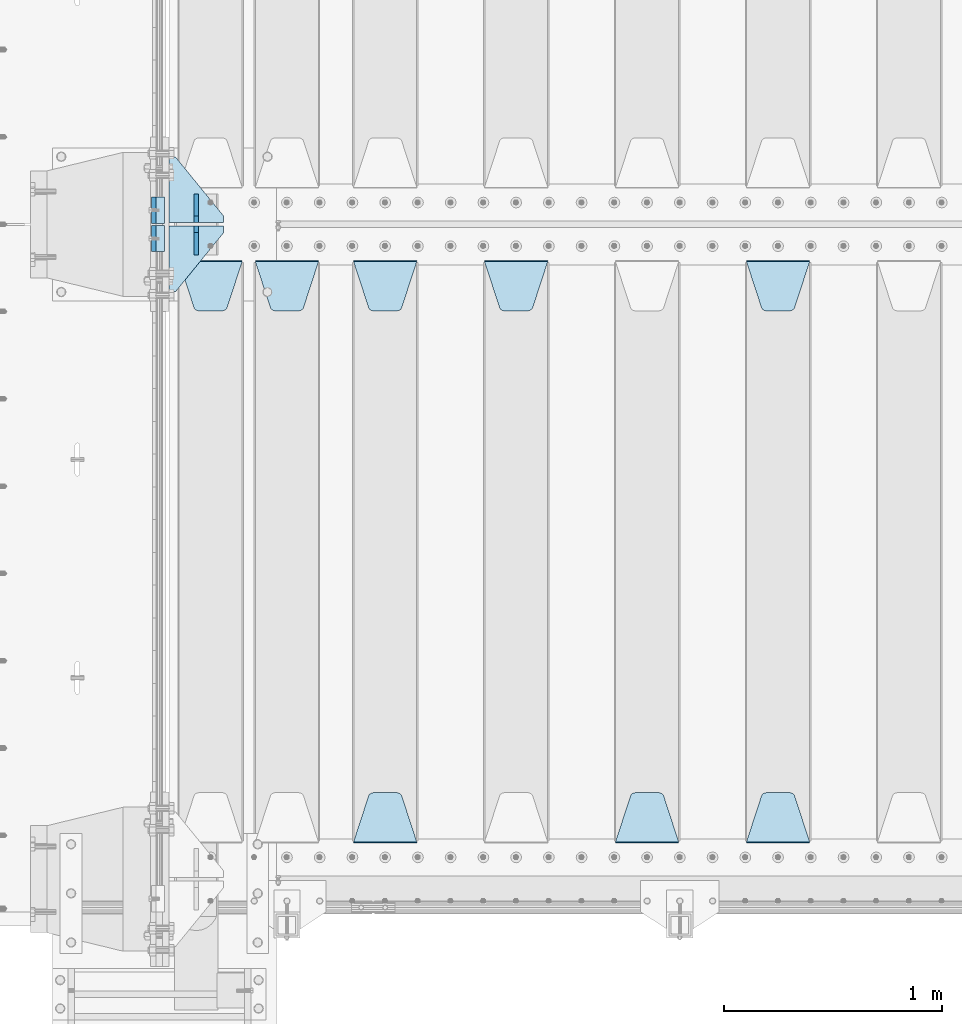
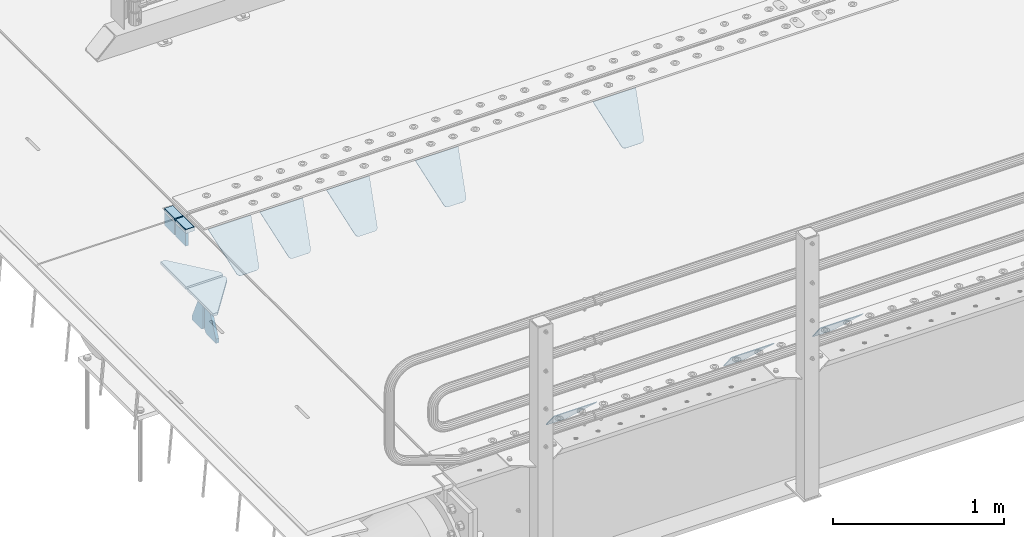
# One storey, part 155 of 193: 16 plates.
"""IFC2X3 building model written with IfcOpenShell, lengths in millimetres."""

from ifc_helpers import new_model, si_unit, frame, origin_with_axes, place, context, subcontext, project, spatial, faceted_brep, material, type_object, element, save


model = new_model("IFC2X3")

# Units and contexts
model_context = context("Model", 3, precision=1e-05, world=origin_with_axes())
body_context = subcontext(model_context, "Body", "Model", "MODEL_VIEW")
ifc_project = project(units=[si_unit("LENGTHUNIT", "METRE", prefix="MILLI"), si_unit("AREAUNIT", "SQUARE_METRE"), si_unit("VOLUMEUNIT", "CUBIC_METRE"), si_unit("MASSUNIT", "GRAM", prefix="KILO"), si_unit("TIMEUNIT", "SECOND"), si_unit("PLANEANGLEUNIT", "RADIAN"), si_unit("SOLIDANGLEUNIT", "STERADIAN"), si_unit("THERMODYNAMICTEMPERATUREUNIT", "DEGREE_CELSIUS"), si_unit("LUMINOUSINTENSITYUNIT", "LUMEN")], contexts=[model_context])

# Site, building, storey
site_placement = place(None, origin_with_axes())
site = spatial("IfcSite", under=ifc_project, at=site_placement, CompositionType="ELEMENT")
building_placement = place(site_placement, origin_with_axes())
building = spatial("IfcBuilding", under=site, at=building_placement, Name="Standard", CompositionType="ELEMENT")
storey_placement = place(building_placement, origin_with_axes())
storey = spatial("IfcBuildingStorey", under=building, at=storey_placement, Name="Undefined", CompositionType="ELEMENT", Elevation=0.0)

# Plates
ifc_material_1 = material()
plate_type_1 = type_object("IfcPlateType", PredefinedType="NOTDEFINED")
plate_1_placement = place(storey_placement, frame((-42460.0, 26935.0000000001, -16.0000763080427), z_axis=(-1.0, 0.0, 0.0), x_axis=(0.0, 0.0, 1.0)))
element("IfcPlate", 1, at=plate_1_placement, inside=storey, type_object=plate_type_1, material=ifc_material_1, context=body_context, shape_type="Brep", body=[
    faceted_brep([(3.5527136788005e-15, -60.0, 0.0), (2.49929144047201e-09, -60.0, 60.0), (2.49929144047201e-09, 60.0000000000036, 60.0), (0.0, 60.0, -7.27595761418343e-12), (25.0146748218828, -60.0, 60.0), (25.0146748218828, 60.0, 60.0), (26.5597449794466, -60.0, 59.7552873949098), (26.5597449794466, 60.0000000000036, 59.7552873949098), (27.9535758796897, -59.9999999999964, 59.0451032832789), (27.9535758796897, 60.0000000000036, 59.0451032832789), (29.0597323263517, -60.0, 57.9389640667287), (29.0597323263517, 60.0, 57.9389640667287), (29.7699381491534, -60.0, 56.5451442289705), (29.7699381491534, 60.0, 56.5451442289705), (30.0146748212763, -60.0, 55.0000778834001), (30.0146748212763, 60.0, 55.0000778834001), (30.0154536553013, -59.9999999999964, 5.00007788340736), (30.0154536553013, 60.0000000000036, 5.00007788340736), (29.7707554908505, -60.0, 3.45497428546514), (29.7707554908505, 60.0, 3.45497428546514), (29.0605660948355, -60.0, 2.06111154406972), (29.0605660948355, 60.0, 2.06111154406972), (27.9544051209123, -59.9999999999964, 0.954933339693525), (27.9544051209123, 60.0000000000036, 0.954933339693525), (26.5605534420796, -60.0, 0.244722232011554), (26.5605534420796, 60.0, 0.244722232011554), (25.0154536559091, -60.0, 7.27595761418343e-12), (25.0154536559091, 60.0, 7.27595761418343e-12)], [[[0, 1, 2, 3]], [[1, 4, 5, 2]], [[4, 6, 7, 5]], [[6, 8, 9, 7]], [[8, 10, 11, 9]], [[10, 12, 13, 11]], [[12, 14, 15, 13]], [[14, 16, 17, 15]], [[16, 18, 19, 17]], [[18, 20, 21, 19]], [[20, 22, 23, 21]], [[22, 24, 25, 23]], [[24, 26, 27, 25]], [[26, 0, 3, 27]], [[5, 7, 9, 11, 13, 15, 17, 19, 21, 23, 25, 27, 3, 2]], [[26, 24, 22, 20, 18, 16, 14, 12, 10, 8, 6, 4, 1, 0]]]),
])
plate_2_placement = place(storey_placement, frame((-42460.0000000646, 27065.0000004321, -15.999743219274), z_axis=(-1.0, 0.0, 0.0), x_axis=(0.0, -4.95099997756316e-06, 0.999999999987744)))
element("IfcPlate", 2, at=plate_2_placement, inside=storey, type_object=plate_type_1, material=ifc_material_1, context=body_context, shape_type="Brep", body=[
    faceted_brep([(3.5527136788005e-15, -60.0, 0.0), (-0.000933120085687023, -60.0, 60.0), (-0.000933120085687023, 60.0, 59.9999999999927), (0.0, 60.0, -7.27595761418343e-12), (24.9991450303709, -60.0, 60.0), (24.9991450303709, 60.0, 59.9999999999927), (26.544215218168, -60.0000000000036, 59.7552873850873), (26.544215218168, 60.0, 59.75528738508), (27.9380461396139, -60.0000000000036, 59.0451032459096), (27.9380461396139, 60.0, 59.0451032459096), (29.0442025908961, -60.0000000000036, 57.9389639895744), (29.0442025908961, 60.0, 57.9389639895744), (29.7544083969366, -60.0, 56.5451441080368), (29.7544083969366, 60.0, 56.5451441080295), (29.9991450297669, -60.0000000000036, 55.0000777244568), (29.9991450297669, 60.0, 55.0000777244495), (29.999922274335, -60.0, 5.00007772445679), (29.999922274335, 59.9999999999964, 5.00007772444951), (29.7552240705896, -60.0, 3.45497416452417), (29.7552240705896, 60.0000000000036, 3.45497416452417), (29.0450346578116, -60.0, 2.06111146690819), (29.0450346578116, 59.9999999999964, 2.06111146690819), (27.9388736885072, -60.0000000000036, 0.954933302316931), (27.9388736885072, 59.9999999999964, 0.954933302316931), (26.5450220308766, -60.0000000000036, 0.244722222181736), (26.5450220308766, 60.0, 0.244722222181736), (24.9999222749392, -60.0, 0.0), (24.9999222749392, 60.0, -7.27595761418343e-12)], [[[0, 1, 2, 3]], [[1, 4, 5, 2]], [[4, 6, 7, 5]], [[6, 8, 9, 7]], [[8, 10, 11, 9]], [[10, 12, 13, 11]], [[12, 14, 15, 13]], [[14, 16, 17, 15]], [[16, 18, 19, 17]], [[18, 20, 21, 19]], [[20, 22, 23, 21]], [[22, 24, 25, 23]], [[24, 26, 27, 25]], [[26, 0, 3, 27]], [[5, 7, 9, 11, 13, 15, 17, 19, 21, 23, 25, 27, 3, 2]], [[26, 24, 22, 20, 18, 16, 14, 12, 10, 8, 6, 4, 1, 0]]]),
])
ifc_material_2 = material(Name="STEEL/S355N")
plate_type_2 = type_object("IfcPlateType", PredefinedType="NOTDEFINED")
plate_3_placement = place(storey_placement, frame((-42510.0, 26995.0000855345, -105.984410846883), z_axis=(0.0, -1.0, 0.0), x_axis=(0.0, 0.0, 1.0)))
element("IfcPlate", 3, at=plate_3_placement, inside=storey, type_object=plate_type_2, material=ifc_material_2, context=body_context, shape_type="Brep", body=[
    faceted_brep([(0.0, -10.0, 0.0), (5.70725632087488e-07, -10.0, 120.0), (5.70725632087488e-07, 10.0, 120.0), (0.0, 10.0, 0.0), (89.9845046997066, -10.0, 120.000000000004), (89.9845046997066, 10.0, 120.000000000004), (89.9843902587891, -10.0, 6.54836185276508e-11), (89.9843902587891, 10.0, 6.54836185276508e-11)], [[[0, 1, 2, 3]], [[1, 4, 5, 2]], [[4, 6, 7, 5]], [[6, 0, 3, 7]], [[5, 7, 3, 2]], [[6, 4, 1, 0]]]),
])
plate_4_placement = place(storey_placement, frame((-42510.0, 27125.0004459811, -106.000068249326), z_axis=(1.0000003385235e-09, -0.999999999987744, -4.95099999993936e-06), x_axis=(0.0, -4.95099997756316e-06, 0.999999999987744)))
element("IfcPlate", 4, at=plate_4_placement, inside=storey, type_object=plate_type_2, material=ifc_material_2, context=body_context, shape_type="Brep", body=[
    faceted_brep([(0.0, -10.0, 0.0), (5.70725632087488e-07, -10.0, 120.0), (5.70725632087488e-07, 10.0, 120.0), (0.0, 10.0, 0.0), (89.9999999999979, -10.0, 120.000000000004), (89.9999999999979, 10.0, 120.000000000004), (90.0, -10.0, 1.09139364212751e-11), (90.0, 10.0, 1.09139364212751e-11)], [[[0, 1, 2, 3]], [[1, 4, 5, 2]], [[4, 6, 7, 5]], [[6, 0, 3, 7]], [[5, 7, 3, 2]], [[6, 4, 1, 0]]]),
])
plate_type_3 = type_object("IfcPlateType", PredefinedType="NOTDEFINED")
plate_5_placement = place(storey_placement, frame((-39795.0, 26831.767766956, -1.76776695296758), z_axis=(0.0, -0.707106781186547, -0.707106781186548), x_axis=(1.0, 0.0, 0.0)))
element("IfcPlate", 5, at=plate_5_placement, inside=storey, type_object=plate_type_3, material=ifc_material_2, context=body_context, shape_type="Brep", body=[
    faceted_brep([(0.0, -2.5, 0.0), (69.345504679477, -2.50000000000364, 300.171731424831), (69.345504679477, 2.49999999999636, 300.171731424831), (0.0, 2.5, 0.0), (70.9274061199576, -2.50000000000364, 304.897442415397), (70.9274061199576, 2.49999999999636, 304.897442415397), (73.3818627772307, -2.50000000000364, 309.234538108529), (73.3818627772307, 2.49999999999636, 309.234538108529), (76.6187032999551, -2.50000000000728, 313.023683126103), (76.6187032999551, 2.49999999999636, 313.023683126103), (80.5190132704993, -2.50000000000364, 316.125672595372), (80.5190132704993, 2.49999999999636, 316.125672595368), (84.9395038596849, -2.50000000000364, 318.426546230472), (84.9395038596849, 2.49999999999636, 318.426546230476), (89.7177759439219, -2.50000000000364, 319.841774983273), (89.7177759439219, 2.49999999999636, 319.841774983277), (94.678286292652, -2.50000000000364, 320.319366455074), (94.678286292652, 2.49999999999636, 320.319366455074), (195.321713707348, -2.50000000000364, 320.319366455074), (195.321713707348, 2.49999999999636, 320.319366455074), (200.282224056078, -2.50000000000364, 319.841774983273), (200.282224056078, 2.49999999999636, 319.841774983277), (205.060496140315, -2.50000000000364, 318.426546230472), (205.060496140315, 2.49999999999636, 318.426546230472), (209.480986729501, -2.50000000000364, 316.125672595372), (209.480986729501, 2.49999999999636, 316.125672595368), (213.381296700045, -2.50000000000728, 313.023683126103), (213.381296700045, 2.49999999999272, 313.023683126103), (216.618137222769, -2.50000000000364, 309.234538108525), (216.618137222769, 2.49999999999636, 309.234538108522), (219.072593880042, -2.50000000000364, 304.897442415397), (219.072593880042, 2.49999999999636, 304.897442415397), (220.654495320523, -2.50000000000364, 300.171731424831), (220.654495320523, 2.49999999999636, 300.171731424831), (290.0, -2.50000000000364, 0.0), (290.0, 2.49999999999636, 0.0)], [[[0, 1, 2, 3]], [[1, 4, 5, 2]], [[4, 6, 7, 5]], [[6, 8, 9, 7]], [[8, 10, 11, 9]], [[10, 12, 13, 11]], [[12, 14, 15, 13]], [[14, 16, 17, 15]], [[16, 18, 19, 17]], [[18, 20, 21, 19]], [[20, 22, 23, 21]], [[22, 24, 25, 23]], [[24, 26, 27, 25]], [[26, 28, 29, 27]], [[28, 30, 31, 29]], [[30, 32, 33, 31]], [[32, 34, 35, 33]], [[34, 0, 3, 35]], [[5, 7, 9, 11, 13, 15, 17, 19, 21, 23, 25, 27, 29, 31, 33, 35, 3, 2]], [[34, 32, 30, 28, 26, 24, 22, 20, 18, 16, 14, 12, 10, 8, 6, 4, 1, 0]]]),
])
plate_6_placement = place(storey_placement, frame((-39505.0, 24168.232233047, -1.76776695296758), z_axis=(0.0, 0.707106781186547, -0.707106781186548), x_axis=(-1.0, 0.0, 0.0)))
element("IfcPlate", 6, at=plate_6_placement, inside=storey, type_object=plate_type_3, material=ifc_material_2, context=body_context, shape_type="Brep", body=[
    faceted_brep([(0.0, -2.5, 0.0), (69.345504679477, -2.50000000000364, 300.171731424831), (69.345504679477, 2.49999999999636, 300.171731424831), (0.0, 2.5, 0.0), (70.9274061199576, -2.50000000000364, 304.897442415397), (70.9274061199576, 2.49999999999636, 304.897442415397), (73.3818627772307, -2.50000000000364, 309.234538108529), (73.3818627772307, 2.49999999999636, 309.234538108529), (76.6187032999551, -2.50000000000728, 313.023683126103), (76.6187032999551, 2.49999999999636, 313.023683126103), (80.5190132704993, -2.50000000000364, 316.125672595372), (80.5190132704993, 2.49999999999636, 316.125672595368), (84.9395038596849, -2.50000000000364, 318.426546230472), (84.9395038596849, 2.49999999999636, 318.426546230476), (89.7177759439219, -2.50000000000364, 319.841774983273), (89.7177759439219, 2.49999999999636, 319.841774983277), (94.678286292652, -2.50000000000364, 320.319366455074), (94.678286292652, 2.49999999999636, 320.319366455074), (195.321713707348, -2.50000000000364, 320.319366455074), (195.321713707348, 2.49999999999636, 320.319366455074), (200.282224056078, -2.50000000000364, 319.841774983273), (200.282224056078, 2.49999999999636, 319.841774983277), (205.060496140315, -2.50000000000364, 318.426546230472), (205.060496140315, 2.49999999999636, 318.426546230472), (209.480986729501, -2.50000000000364, 316.125672595372), (209.480986729501, 2.49999999999636, 316.125672595368), (213.381296700045, -2.50000000000728, 313.023683126103), (213.381296700045, 2.49999999999272, 313.023683126103), (216.618137222769, -2.50000000000364, 309.234538108525), (216.618137222769, 2.49999999999636, 309.234538108522), (219.072593880042, -2.50000000000364, 304.897442415397), (219.072593880042, 2.49999999999636, 304.897442415397), (220.654495320523, -2.50000000000364, 300.171731424831), (220.654495320523, 2.49999999999636, 300.171731424831), (290.0, -2.50000000000364, 0.0), (290.0, 2.49999999999636, 0.0)], [[[0, 1, 2, 3]], [[1, 4, 5, 2]], [[4, 6, 7, 5]], [[6, 8, 9, 7]], [[8, 10, 11, 9]], [[10, 12, 13, 11]], [[12, 14, 15, 13]], [[14, 16, 17, 15]], [[16, 18, 19, 17]], [[18, 20, 21, 19]], [[20, 22, 23, 21]], [[22, 24, 25, 23]], [[24, 26, 27, 25]], [[26, 28, 29, 27]], [[28, 30, 31, 29]], [[30, 32, 33, 31]], [[32, 34, 35, 33]], [[34, 0, 3, 35]], [[5, 7, 9, 11, 13, 15, 17, 19, 21, 23, 25, 27, 29, 31, 33, 35, 3, 2]], [[34, 32, 30, 28, 26, 24, 22, 20, 18, 16, 14, 12, 10, 8, 6, 4, 1, 0]]]),
])
plate_7_placement = place(storey_placement, frame((-40105.0, 24168.232233047, -1.76776695296758), z_axis=(0.0, 0.707106781186547, -0.707106781186548), x_axis=(-1.0, 0.0, 0.0)))
element("IfcPlate", 7, at=plate_7_placement, inside=storey, type_object=plate_type_3, material=ifc_material_2, context=body_context, shape_type="Brep", body=[
    faceted_brep([(0.0, -2.5, 0.0), (69.345504679477, -2.50000000000364, 300.171731424831), (69.345504679477, 2.49999999999636, 300.171731424831), (0.0, 2.5, 0.0), (70.9274061199576, -2.50000000000364, 304.897442415397), (70.9274061199576, 2.49999999999636, 304.897442415397), (73.3818627772307, -2.50000000000364, 309.234538108529), (73.3818627772307, 2.49999999999636, 309.234538108529), (76.6187032999551, -2.50000000000728, 313.023683126103), (76.6187032999551, 2.49999999999636, 313.023683126103), (80.5190132704993, -2.50000000000364, 316.125672595372), (80.5190132704993, 2.49999999999636, 316.125672595368), (84.9395038596849, -2.50000000000364, 318.426546230472), (84.9395038596849, 2.49999999999636, 318.426546230476), (89.7177759439219, -2.50000000000364, 319.841774983273), (89.7177759439219, 2.49999999999636, 319.841774983277), (94.678286292652, -2.50000000000364, 320.319366455074), (94.678286292652, 2.49999999999636, 320.319366455074), (195.321713707348, -2.50000000000364, 320.319366455074), (195.321713707348, 2.49999999999636, 320.319366455074), (200.282224056078, -2.50000000000364, 319.841774983273), (200.282224056078, 2.49999999999636, 319.841774983277), (205.060496140315, -2.50000000000364, 318.426546230472), (205.060496140315, 2.49999999999636, 318.426546230472), (209.480986729501, -2.50000000000364, 316.125672595372), (209.480986729501, 2.49999999999636, 316.125672595368), (213.381296700045, -2.50000000000728, 313.023683126103), (213.381296700045, 2.49999999999272, 313.023683126103), (216.618137222769, -2.50000000000364, 309.234538108525), (216.618137222769, 2.49999999999636, 309.234538108522), (219.072593880042, -2.50000000000364, 304.897442415397), (219.072593880042, 2.49999999999636, 304.897442415397), (220.654495320523, -2.50000000000364, 300.171731424831), (220.654495320523, 2.49999999999636, 300.171731424831), (290.0, -2.50000000000364, 0.0), (290.0, 2.49999999999636, 0.0)], [[[0, 1, 2, 3]], [[1, 4, 5, 2]], [[4, 6, 7, 5]], [[6, 8, 9, 7]], [[8, 10, 11, 9]], [[10, 12, 13, 11]], [[12, 14, 15, 13]], [[14, 16, 17, 15]], [[16, 18, 19, 17]], [[18, 20, 21, 19]], [[20, 22, 23, 21]], [[22, 24, 25, 23]], [[24, 26, 27, 25]], [[26, 28, 29, 27]], [[28, 30, 31, 29]], [[30, 32, 33, 31]], [[32, 34, 35, 33]], [[34, 0, 3, 35]], [[5, 7, 9, 11, 13, 15, 17, 19, 21, 23, 25, 27, 29, 31, 33, 35, 3, 2]], [[34, 32, 30, 28, 26, 24, 22, 20, 18, 16, 14, 12, 10, 8, 6, 4, 1, 0]]]),
])
plate_8_placement = place(storey_placement, frame((-40995.0, 26831.767766956, -1.76776695296758), z_axis=(0.0, -0.707106781186547, -0.707106781186548), x_axis=(1.0, 0.0, 0.0)))
element("IfcPlate", 8, at=plate_8_placement, inside=storey, type_object=plate_type_3, material=ifc_material_2, context=body_context, shape_type="Brep", body=[
    faceted_brep([(0.0, -2.5, 0.0), (69.345504679477, -2.50000000000364, 300.171731424831), (69.345504679477, 2.49999999999636, 300.171731424831), (0.0, 2.5, 0.0), (70.9274061199576, -2.50000000000364, 304.897442415397), (70.9274061199576, 2.49999999999636, 304.897442415397), (73.3818627772307, -2.50000000000364, 309.234538108529), (73.3818627772307, 2.49999999999636, 309.234538108529), (76.6187032999551, -2.50000000000728, 313.023683126103), (76.6187032999551, 2.49999999999636, 313.023683126103), (80.5190132704993, -2.50000000000364, 316.125672595372), (80.5190132704993, 2.49999999999636, 316.125672595368), (84.9395038596849, -2.50000000000364, 318.426546230472), (84.9395038596849, 2.49999999999636, 318.426546230476), (89.7177759439219, -2.50000000000364, 319.841774983273), (89.7177759439219, 2.49999999999636, 319.841774983277), (94.678286292652, -2.50000000000364, 320.319366455074), (94.678286292652, 2.49999999999636, 320.319366455074), (195.321713707348, -2.50000000000364, 320.319366455074), (195.321713707348, 2.49999999999636, 320.319366455074), (200.282224056078, -2.50000000000364, 319.841774983273), (200.282224056078, 2.49999999999636, 319.841774983277), (205.060496140315, -2.50000000000364, 318.426546230472), (205.060496140315, 2.49999999999636, 318.426546230472), (209.480986729501, -2.50000000000364, 316.125672595372), (209.480986729501, 2.49999999999636, 316.125672595368), (213.381296700045, -2.50000000000728, 313.023683126103), (213.381296700045, 2.49999999999272, 313.023683126103), (216.618137222769, -2.50000000000364, 309.234538108525), (216.618137222769, 2.49999999999636, 309.234538108522), (219.072593880042, -2.50000000000364, 304.897442415397), (219.072593880042, 2.49999999999636, 304.897442415397), (220.654495320523, -2.50000000000364, 300.171731424831), (220.654495320523, 2.49999999999636, 300.171731424831), (290.0, -2.50000000000364, 0.0), (290.0, 2.49999999999636, 0.0)], [[[0, 1, 2, 3]], [[1, 4, 5, 2]], [[4, 6, 7, 5]], [[6, 8, 9, 7]], [[8, 10, 11, 9]], [[10, 12, 13, 11]], [[12, 14, 15, 13]], [[14, 16, 17, 15]], [[16, 18, 19, 17]], [[18, 20, 21, 19]], [[20, 22, 23, 21]], [[22, 24, 25, 23]], [[24, 26, 27, 25]], [[26, 28, 29, 27]], [[28, 30, 31, 29]], [[30, 32, 33, 31]], [[32, 34, 35, 33]], [[34, 0, 3, 35]], [[5, 7, 9, 11, 13, 15, 17, 19, 21, 23, 25, 27, 29, 31, 33, 35, 3, 2]], [[34, 32, 30, 28, 26, 24, 22, 20, 18, 16, 14, 12, 10, 8, 6, 4, 1, 0]]]),
])
plate_9_placement = place(storey_placement, frame((-41595.0, 26831.767766956, -1.76776695296758), z_axis=(0.0, -0.707106781186547, -0.707106781186548), x_axis=(1.0, 0.0, 0.0)))
element("IfcPlate", 9, at=plate_9_placement, inside=storey, type_object=plate_type_3, material=ifc_material_2, context=body_context, shape_type="Brep", body=[
    faceted_brep([(0.0, -2.5, 0.0), (69.345504679477, -2.50000000000364, 300.171731424831), (69.345504679477, 2.49999999999636, 300.171731424831), (0.0, 2.5, 0.0), (70.9274061199576, -2.50000000000364, 304.897442415397), (70.9274061199576, 2.49999999999636, 304.897442415397), (73.3818627772307, -2.50000000000364, 309.234538108529), (73.3818627772307, 2.49999999999636, 309.234538108529), (76.6187032999551, -2.50000000000728, 313.023683126103), (76.6187032999551, 2.49999999999636, 313.023683126103), (80.5190132704993, -2.50000000000364, 316.125672595372), (80.5190132704993, 2.49999999999636, 316.125672595368), (84.9395038596849, -2.50000000000364, 318.426546230472), (84.9395038596849, 2.49999999999636, 318.426546230476), (89.7177759439219, -2.50000000000364, 319.841774983273), (89.7177759439219, 2.49999999999636, 319.841774983277), (94.678286292652, -2.50000000000364, 320.319366455074), (94.678286292652, 2.49999999999636, 320.319366455074), (195.321713707348, -2.50000000000364, 320.319366455074), (195.321713707348, 2.49999999999636, 320.319366455074), (200.282224056078, -2.50000000000364, 319.841774983273), (200.282224056078, 2.49999999999636, 319.841774983277), (205.060496140315, -2.50000000000364, 318.426546230472), (205.060496140315, 2.49999999999636, 318.426546230472), (209.480986729501, -2.50000000000364, 316.125672595372), (209.480986729501, 2.49999999999636, 316.125672595368), (213.381296700045, -2.50000000000728, 313.023683126103), (213.381296700045, 2.49999999999272, 313.023683126103), (216.618137222769, -2.50000000000364, 309.234538108525), (216.618137222769, 2.49999999999636, 309.234538108522), (219.072593880042, -2.50000000000364, 304.897442415397), (219.072593880042, 2.49999999999636, 304.897442415397), (220.654495320523, -2.50000000000364, 300.171731424831), (220.654495320523, 2.49999999999636, 300.171731424831), (290.0, -2.50000000000364, 0.0), (290.0, 2.49999999999636, 0.0)], [[[0, 1, 2, 3]], [[1, 4, 5, 2]], [[4, 6, 7, 5]], [[6, 8, 9, 7]], [[8, 10, 11, 9]], [[10, 12, 13, 11]], [[12, 14, 15, 13]], [[14, 16, 17, 15]], [[16, 18, 19, 17]], [[18, 20, 21, 19]], [[20, 22, 23, 21]], [[22, 24, 25, 23]], [[24, 26, 27, 25]], [[26, 28, 29, 27]], [[28, 30, 31, 29]], [[30, 32, 33, 31]], [[32, 34, 35, 33]], [[34, 0, 3, 35]], [[5, 7, 9, 11, 13, 15, 17, 19, 21, 23, 25, 27, 29, 31, 33, 35, 3, 2]], [[34, 32, 30, 28, 26, 24, 22, 20, 18, 16, 14, 12, 10, 8, 6, 4, 1, 0]]]),
])
plate_10_placement = place(storey_placement, frame((-41305.0, 24168.232233047, -1.76776695296758), z_axis=(0.0, 0.707106781186547, -0.707106781186548), x_axis=(-1.0, 0.0, 0.0)))
element("IfcPlate", 10, at=plate_10_placement, inside=storey, type_object=plate_type_3, material=ifc_material_2, context=body_context, shape_type="Brep", body=[
    faceted_brep([(0.0, -2.5, 0.0), (69.345504679477, -2.50000000000364, 300.171731424831), (69.345504679477, 2.49999999999636, 300.171731424831), (0.0, 2.5, 0.0), (70.9274061199576, -2.50000000000364, 304.897442415397), (70.9274061199576, 2.49999999999636, 304.897442415397), (73.3818627772307, -2.50000000000364, 309.234538108529), (73.3818627772307, 2.49999999999636, 309.234538108529), (76.6187032999551, -2.50000000000728, 313.023683126103), (76.6187032999551, 2.49999999999636, 313.023683126103), (80.5190132704993, -2.50000000000364, 316.125672595372), (80.5190132704993, 2.49999999999636, 316.125672595368), (84.9395038596849, -2.50000000000364, 318.426546230472), (84.9395038596849, 2.49999999999636, 318.426546230476), (89.7177759439219, -2.50000000000364, 319.841774983273), (89.7177759439219, 2.49999999999636, 319.841774983277), (94.678286292652, -2.50000000000364, 320.319366455074), (94.678286292652, 2.49999999999636, 320.319366455074), (195.321713707348, -2.50000000000364, 320.319366455074), (195.321713707348, 2.49999999999636, 320.319366455074), (200.282224056078, -2.50000000000364, 319.841774983273), (200.282224056078, 2.49999999999636, 319.841774983277), (205.060496140315, -2.50000000000364, 318.426546230472), (205.060496140315, 2.49999999999636, 318.426546230472), (209.480986729501, -2.50000000000364, 316.125672595372), (209.480986729501, 2.49999999999636, 316.125672595368), (213.381296700045, -2.50000000000728, 313.023683126103), (213.381296700045, 2.49999999999272, 313.023683126103), (216.618137222769, -2.50000000000364, 309.234538108525), (216.618137222769, 2.49999999999636, 309.234538108522), (219.072593880042, -2.50000000000364, 304.897442415397), (219.072593880042, 2.49999999999636, 304.897442415397), (220.654495320523, -2.50000000000364, 300.171731424831), (220.654495320523, 2.49999999999636, 300.171731424831), (290.0, -2.50000000000364, 0.0), (290.0, 2.49999999999636, 0.0)], [[[0, 1, 2, 3]], [[1, 4, 5, 2]], [[4, 6, 7, 5]], [[6, 8, 9, 7]], [[8, 10, 11, 9]], [[10, 12, 13, 11]], [[12, 14, 15, 13]], [[14, 16, 17, 15]], [[16, 18, 19, 17]], [[18, 20, 21, 19]], [[20, 22, 23, 21]], [[22, 24, 25, 23]], [[24, 26, 27, 25]], [[26, 28, 29, 27]], [[28, 30, 31, 29]], [[30, 32, 33, 31]], [[32, 34, 35, 33]], [[34, 0, 3, 35]], [[5, 7, 9, 11, 13, 15, 17, 19, 21, 23, 25, 27, 29, 31, 33, 35, 3, 2]], [[34, 32, 30, 28, 26, 24, 22, 20, 18, 16, 14, 12, 10, 8, 6, 4, 1, 0]]]),
])
plate_11_placement = place(storey_placement, frame((-42045.0, 26831.767766956, -1.76776695296758), z_axis=(0.0, -0.707106781186547, -0.707106781186548), x_axis=(1.0, 0.0, 0.0)))
element("IfcPlate", 11, at=plate_11_placement, inside=storey, type_object=plate_type_3, material=ifc_material_2, context=body_context, shape_type="Brep", body=[
    faceted_brep([(0.0, -2.5, 0.0), (69.345504679477, -2.50000000000364, 300.171731424831), (69.345504679477, 2.49999999999636, 300.171731424831), (0.0, 2.5, 0.0), (70.9274061199576, -2.50000000000364, 304.897442415397), (70.9274061199576, 2.49999999999636, 304.897442415397), (73.3818627772307, -2.50000000000364, 309.234538108529), (73.3818627772307, 2.49999999999636, 309.234538108529), (76.6187032999551, -2.50000000000728, 313.023683126103), (76.6187032999551, 2.49999999999636, 313.023683126103), (80.5190132704993, -2.50000000000364, 316.125672595372), (80.5190132704993, 2.49999999999636, 316.125672595368), (84.9395038596849, -2.50000000000364, 318.426546230472), (84.9395038596849, 2.49999999999636, 318.426546230476), (89.7177759439219, -2.50000000000364, 319.841774983273), (89.7177759439219, 2.49999999999636, 319.841774983277), (94.678286292652, -2.50000000000364, 320.319366455074), (94.678286292652, 2.49999999999636, 320.319366455074), (195.321713707348, -2.50000000000364, 320.319366455074), (195.321713707348, 2.49999999999636, 320.319366455074), (200.282224056078, -2.50000000000364, 319.841774983273), (200.282224056078, 2.49999999999636, 319.841774983277), (205.060496140315, -2.50000000000364, 318.426546230472), (205.060496140315, 2.49999999999636, 318.426546230472), (209.480986729501, -2.50000000000364, 316.125672595372), (209.480986729501, 2.49999999999636, 316.125672595368), (213.381296700045, -2.50000000000728, 313.023683126103), (213.381296700045, 2.49999999999272, 313.023683126103), (216.618137222769, -2.50000000000364, 309.234538108525), (216.618137222769, 2.49999999999636, 309.234538108522), (219.072593880042, -2.50000000000364, 304.897442415397), (219.072593880042, 2.49999999999636, 304.897442415397), (220.654495320523, -2.50000000000364, 300.171731424831), (220.654495320523, 2.49999999999636, 300.171731424831), (290.0, -2.50000000000364, 0.0), (290.0, 2.49999999999636, 0.0)], [[[0, 1, 2, 3]], [[1, 4, 5, 2]], [[4, 6, 7, 5]], [[6, 8, 9, 7]], [[8, 10, 11, 9]], [[10, 12, 13, 11]], [[12, 14, 15, 13]], [[14, 16, 17, 15]], [[16, 18, 19, 17]], [[18, 20, 21, 19]], [[20, 22, 23, 21]], [[22, 24, 25, 23]], [[24, 26, 27, 25]], [[26, 28, 29, 27]], [[28, 30, 31, 29]], [[30, 32, 33, 31]], [[32, 34, 35, 33]], [[34, 0, 3, 35]], [[5, 7, 9, 11, 13, 15, 17, 19, 21, 23, 25, 27, 29, 31, 33, 35, 3, 2]], [[34, 32, 30, 28, 26, 24, 22, 20, 18, 16, 14, 12, 10, 8, 6, 4, 1, 0]]]),
])
plate_12_placement = place(storey_placement, frame((-42395.0, 26831.767766956, -1.76776695296758), z_axis=(0.0, -0.707106781186547, -0.707106781186548), x_axis=(1.0, 0.0, 0.0)))
element("IfcPlate", 12, at=plate_12_placement, inside=storey, type_object=plate_type_3, material=ifc_material_2, context=body_context, shape_type="Brep", body=[
    faceted_brep([(0.0, -2.5, 0.0), (69.345504679477, -2.50000000000364, 300.171731424831), (69.345504679477, 2.49999999999636, 300.171731424831), (0.0, 2.5, 0.0), (70.9274061199576, -2.50000000000364, 304.897442415397), (70.9274061199576, 2.49999999999636, 304.897442415397), (73.3818627772307, -2.50000000000364, 309.234538108529), (73.3818627772307, 2.49999999999636, 309.234538108529), (76.6187032999551, -2.50000000000728, 313.023683126103), (76.6187032999551, 2.49999999999636, 313.023683126103), (80.5190132704993, -2.50000000000364, 316.125672595372), (80.5190132704993, 2.49999999999636, 316.125672595368), (84.9395038596849, -2.50000000000364, 318.426546230472), (84.9395038596849, 2.49999999999636, 318.426546230476), (89.7177759439219, -2.50000000000364, 319.841774983273), (89.7177759439219, 2.49999999999636, 319.841774983277), (94.678286292652, -2.50000000000364, 320.319366455074), (94.678286292652, 2.49999999999636, 320.319366455074), (195.321713707348, -2.50000000000364, 320.319366455074), (195.321713707348, 2.49999999999636, 320.319366455074), (200.282224056078, -2.50000000000364, 319.841774983273), (200.282224056078, 2.49999999999636, 319.841774983277), (205.060496140315, -2.50000000000364, 318.426546230472), (205.060496140315, 2.49999999999636, 318.426546230472), (209.480986729501, -2.50000000000364, 316.125672595372), (209.480986729501, 2.49999999999636, 316.125672595368), (213.381296700045, -2.50000000000728, 313.023683126103), (213.381296700045, 2.49999999999272, 313.023683126103), (216.618137222769, -2.50000000000364, 309.234538108525), (216.618137222769, 2.49999999999636, 309.234538108522), (219.072593880042, -2.50000000000364, 304.897442415397), (219.072593880042, 2.49999999999636, 304.897442415397), (220.654495320523, -2.50000000000364, 300.171731424831), (220.654495320523, 2.49999999999636, 300.171731424831), (290.0, -2.50000000000364, 0.0), (290.0, 2.49999999999636, 0.0)], [[[0, 1, 2, 3]], [[1, 4, 5, 2]], [[4, 6, 7, 5]], [[6, 8, 9, 7]], [[8, 10, 11, 9]], [[10, 12, 13, 11]], [[12, 14, 15, 13]], [[14, 16, 17, 15]], [[16, 18, 19, 17]], [[18, 20, 21, 19]], [[20, 22, 23, 21]], [[22, 24, 25, 23]], [[24, 26, 27, 25]], [[26, 28, 29, 27]], [[28, 30, 31, 29]], [[30, 32, 33, 31]], [[32, 34, 35, 33]], [[34, 0, 3, 35]], [[5, 7, 9, 11, 13, 15, 17, 19, 21, 23, 25, 27, 29, 31, 33, 35, 3, 2]], [[34, 32, 30, 28, 26, 24, 22, 20, 18, 16, 14, 12, 10, 8, 6, 4, 1, 0]]]),
])
plate_type_4 = type_object("IfcPlateType", PredefinedType="NOTDEFINED")
for number, where, z_axis, x_axis in (
    (13, (-42190.0, 27008.0, -515.0), (0.0, 1.0, 0.0), (-1.0, 0.0, 0.0)),
    (14, (-42190.0, 26992.0, -515.0), (0.0, -1.0, 0.0), (-1.0, 0.0, 0.0)),
):
    element("IfcPlate", number, at=place(storey_placement, frame(where, z_axis=z_axis, x_axis=x_axis)), inside=storey, type_object=plate_type_4, material=ifc_material_2, context=body_context, shape_type="Brep", body=[
        faceted_brep([(0.0, -10.0, 0.0), (0.0, -10.0, 30.0), (0.0, 10.0, 30.0), (0.0, 10.0, 0.0), (220.0, -10.0, 300.0), (220.0, 10.0, 300.0), (250.0, -10.0, 300.0), (250.0, 10.0, 300.0), (250.0, -10.0, 0.0), (250.0, 10.0, 0.0)], [[[0, 1, 2, 3]], [[1, 4, 5, 2]], [[4, 6, 7, 5]], [[6, 8, 9, 7]], [[8, 0, 3, 9]], [[5, 7, 9, 3, 2]], [[8, 6, 4, 1, 0]]]),
    ])
plate_type_5 = type_object("IfcPlateType", PredefinedType="NOTDEFINED")
for number, where, z_axis, x_axis in (
    (15, (-42315.0, 26860.0, -860.0), (0.0, 0.0, 1.0), (0.0, 1.0, 0.0)),
    (16, (-42315.0, 27140.0, -860.0), (0.0, 0.0, 1.0), (0.0, -1.0, 0.0)),
):
    element("IfcPlate", number, at=place(storey_placement, frame(where, z_axis=z_axis, x_axis=x_axis)), inside=storey, type_object=plate_type_5, material=ifc_material_2, context=body_context, shape_type="Brep", body=[
        faceted_brep([(0.0, -10.0, 0.0), (0.0, -10.0, 30.0), (0.0, 10.0, 30.0), (0.0, 10.0, 0.0), (102.0, -10.0, 250.0), (102.0, 10.0, 250.0), (132.0, -10.0, 250.0), (132.0, 10.0, 250.0), (132.0, -10.0, 30.0), (132.0, 10.0, 30.0), (131.544232590368, -10.0, 24.790554669992), (131.544232590368, 10.0, 24.790554669992), (130.190778623579, -10.0, 19.7393957002299), (130.190778623579, 10.0, 19.7393957002299), (127.980762113533, -10.0, 15.0), (127.980762113533, 10.0, 15.0), (124.98133329357, -10.0, 10.7163717094038), (124.98133329357, 10.0, 10.7163717094038), (121.283628290596, -10.0, 7.01866670643062), (121.283628290596, 10.0, 7.01866670643062), (117.0, -10.0, 4.01923788646684), (117.0, 10.0, 4.01923788646684), (112.260604299769, -10.0, 1.80922137642278), (112.260604299769, 10.0, 1.80922137642278), (107.209445330009, -10.0, 0.455767409633722), (107.209445330009, 10.0, 0.455767409633722), (102.0, -10.0, 0.0), (102.0, 10.0, 0.0)], [[[0, 1, 2, 3]], [[1, 4, 5, 2]], [[4, 6, 7, 5]], [[6, 8, 9, 7]], [[8, 10, 11, 9]], [[10, 12, 13, 11]], [[12, 14, 15, 13]], [[14, 16, 17, 15]], [[16, 18, 19, 17]], [[18, 20, 21, 19]], [[20, 22, 23, 21]], [[22, 24, 25, 23]], [[24, 26, 27, 25]], [[26, 0, 3, 27]], [[5, 7, 9, 11, 13, 15, 17, 19, 21, 23, 25, 27, 3, 2]], [[26, 24, 22, 20, 18, 16, 14, 12, 10, 8, 6, 4, 1, 0]]]),
    ])

save(model, "model.ifc")
